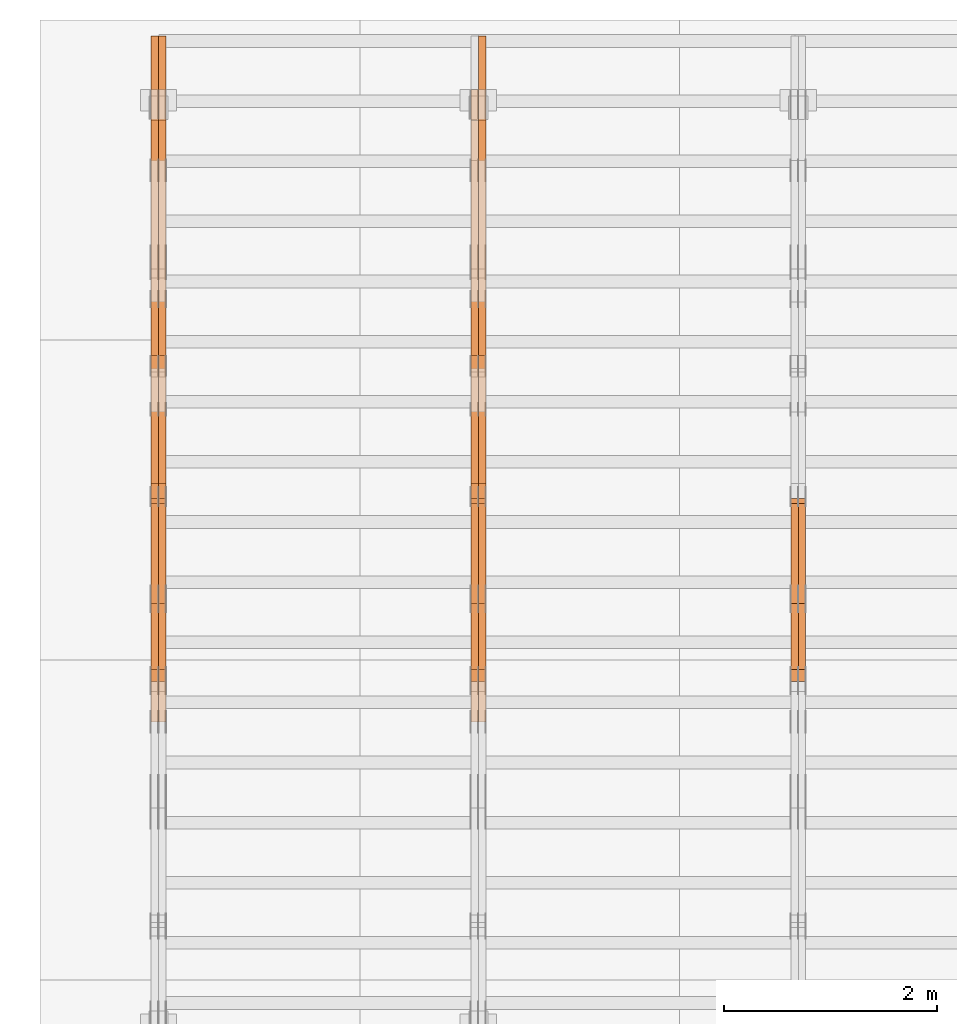
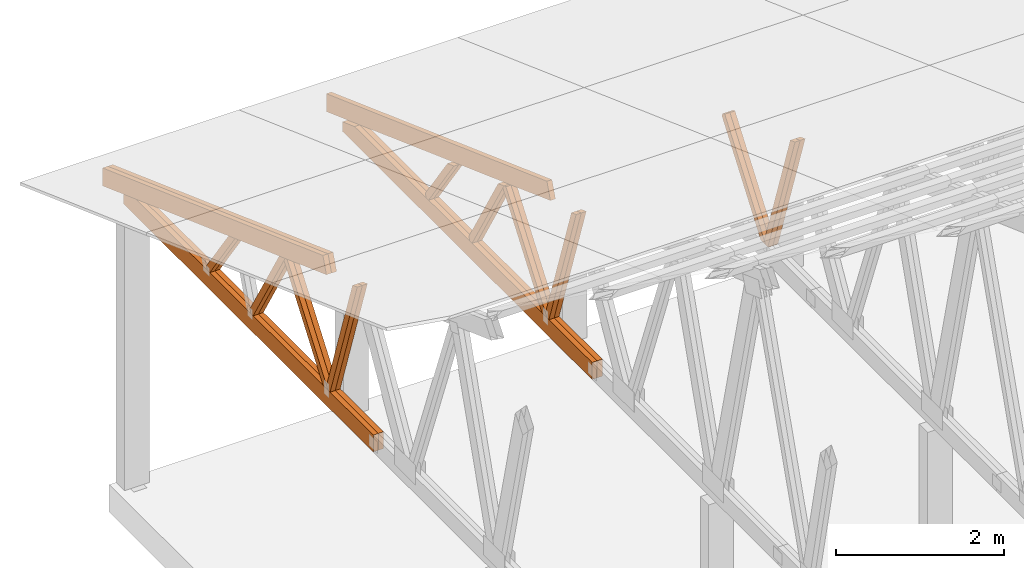
# One storey, part 35 of 189: 27 proxies.
"""IFC2X3 building model written with IfcOpenShell, lengths in millimetres."""

from ifc_helpers import new_model, entity, si_unit, converted_unit, derived_unit, direction, frame, origin, place, context, subcontext, project, spatial, polyline, outline, extrude, source, transform, mapped, material, type_object, type_shapes, element, save


model = new_model("IFC2X3")

# Units and contexts
model_context = context("Model", 3, precision=0.01, world=origin(), true_north=direction((6.12303176911189e-17, 1.0)))
body_context = subcontext(model_context, "Body", "Model", "MODEL_VIEW")
ifc_project = project(units=[si_unit("LENGTHUNIT", "METRE", prefix="MILLI"), si_unit("AREAUNIT", "SQUARE_METRE"), si_unit("VOLUMEUNIT", "CUBIC_METRE"), converted_unit("PLANEANGLEUNIT", "DEGREE", entity("IfcRatioMeasure", 0.0174532925199433), si_unit("PLANEANGLEUNIT", "RADIAN"), dimensions=[0, 0, 0, 0, 0, 0, 0]), si_unit("MASSUNIT", "GRAM", prefix="KILO"), derived_unit("MASSDENSITYUNIT", [(si_unit("MASSUNIT", "GRAM", prefix="KILO"), 1), (si_unit("LENGTHUNIT", "METRE"), -3)]), si_unit("TIMEUNIT", "SECOND"), si_unit("FREQUENCYUNIT", "HERTZ"), si_unit("THERMODYNAMICTEMPERATUREUNIT", "DEGREE_CELSIUS"), derived_unit("THERMALTRANSMITTANCEUNIT", [(si_unit("MASSUNIT", "GRAM", prefix="KILO"), 1), (si_unit("THERMODYNAMICTEMPERATUREUNIT", "KELVIN"), -1), (si_unit("TIMEUNIT", "SECOND"), -3)]), derived_unit("VOLUMETRICFLOWRATEUNIT", [(si_unit("LENGTHUNIT", "METRE"), 3), (si_unit("TIMEUNIT", "SECOND"), -1)]), si_unit("ELECTRICCURRENTUNIT", "AMPERE"), si_unit("ELECTRICVOLTAGEUNIT", "VOLT"), si_unit("POWERUNIT", "WATT"), si_unit("FORCEUNIT", "NEWTON"), si_unit("ILLUMINANCEUNIT", "LUX"), si_unit("LUMINOUSFLUXUNIT", "LUMEN"), si_unit("LUMINOUSINTENSITYUNIT", "CANDELA"), derived_unit("USERDEFINED", [(si_unit("MASSUNIT", "GRAM", prefix="KILO"), -1), (si_unit("LENGTHUNIT", "METRE"), -2), (si_unit("TIMEUNIT", "SECOND"), 3), (si_unit("LUMINOUSFLUXUNIT", "LUMEN"), 1)]), derived_unit("LINEARVELOCITYUNIT", [(si_unit("LENGTHUNIT", "METRE"), 1), (si_unit("TIMEUNIT", "SECOND"), -1)]), si_unit("PRESSUREUNIT", "PASCAL"), derived_unit("USERDEFINED", [(si_unit("LENGTHUNIT", "METRE"), -2), (si_unit("MASSUNIT", "GRAM", prefix="KILO"), 1), (si_unit("TIMEUNIT", "SECOND"), -2)])], contexts=[model_context])

# Site, building, storey
site_placement = place(None, origin())
site = spatial("IfcSite", under=ifc_project, at=site_placement, CompositionType="ELEMENT")
building_placement = place(site_placement, origin())
building = spatial("IfcBuilding", under=site, at=building_placement, CompositionType="ELEMENT")
storey_placement = place(building_placement, origin())
storey = spatial("IfcBuildingStorey", under=building, at=storey_placement, Name="Default", CompositionType="ELEMENT", Elevation=0.0)

# Proxies
ifc_material_1 = material(Name="IfcSurfaceStyle #34810")
building_element_proxy_type_1 = type_object("IfcBuildingElementProxyType", Name="T1-W9 34808", PredefinedType="NOTDEFINED", material=ifc_material_1)
shared_shape_1 = source(origin(), body_context, "Body", "SweptSolid", [
    extrude(outline(polyline([(-1151.44310138162, -47.5000079487596), (776.329826327547, -47.5000079487596), (809.267611644053, -8.1966354137375e-07), (793.242530238244, 47.5000083585914), (-1227.39686682822, 47.5000083585914), (-1151.44310138162, -47.5000079487596)])), frame((809.267685789073, 47.5000083585914, 0.0), z_axis=(0.0, 0.0, 1.0), x_axis=(-1.0, 0.0, 0.0)), (0.0, 0.0, 1.0), 69.9999999999999),
])
type_shapes(building_element_proxy_type_1, [shared_shape_1])
proxy_1_placement = place(building_placement, frame((6335.0, 24600.2198992919, 229.815691184017), z_axis=(-1.0, 0.0, 0.0), x_axis=(0.0, -0.31966811847134, 0.947529574226047)))
element("IfcBuildingElementProxy", 1, at=proxy_1_placement, inside=storey, type_object=building_element_proxy_type_1, material=ifc_material_1, Name="T1-W9", context=body_context, shape_type="MappedRepresentation", body=[
    mapped(shared_shape_1, transform((0.0, 0.0, 0.0), scale=1.0)),
])
ifc_material_2 = material(Name="IfcSurfaceStyle #34744")
building_element_proxy_type_2 = type_object("IfcBuildingElementProxyType", Name="T1-W9 34742", PredefinedType="NOTDEFINED", material=ifc_material_2)
shared_shape_2 = source(origin(), body_context, "Body", "SweptSolid", [
    extrude(outline(polyline([(-1151.44310138162, -47.5000079487596), (776.329826327547, -47.5000079487596), (809.267611644053, -8.1966354137375e-07), (793.242530238244, 47.5000083585914), (-1227.39686682822, 47.5000083585914), (-1151.44310138162, -47.5000079487596)])), frame((809.267685789073, 47.5000083585914, 0.0), z_axis=(0.0, 0.0, 1.0), x_axis=(-1.0, 0.0, 0.0)), (0.0, 0.0, 1.0), 69.9999999999999),
])
type_shapes(building_element_proxy_type_2, [shared_shape_2])
proxy_2_placement = place(building_placement, frame((6265.0, 24600.2198992919, 229.815691184017), z_axis=(-1.0, 0.0, 0.0), x_axis=(0.0, -0.31966811847134, 0.947529574226047)))
element("IfcBuildingElementProxy", 2, at=proxy_2_placement, inside=storey, type_object=building_element_proxy_type_2, material=ifc_material_2, Name="T1-W9", context=body_context, shape_type="MappedRepresentation", body=[
    mapped(shared_shape_2, transform((0.0, 0.0, 0.0), scale=1.0)),
])
ifc_material_3 = material(Name="IfcSurfaceStyle #34546")
building_element_proxy_type_3 = type_object("IfcBuildingElementProxyType", Name="T1-W10 34544", PredefinedType="NOTDEFINED", material=ifc_material_3)
shared_shape_3 = source(origin(), body_context, "Body", "SweptSolid", [
    extrude(outline(polyline([(-993.240970354386, -47.5000757607337), (635.890952815036, -47.5000757607337), (650.068145237537, -1.47580554758164e-05), (629.921374092803, 47.5000831397614), (-922.639501790989, 47.5000831397614), (-993.240970354386, -47.5000757607337)])), frame((650.068173419645, 47.5002811208496, 0.0), z_axis=(0.0, 0.0, 1.0), x_axis=(-1.0, 0.0, 0.0)), (0.0, 0.0, 1.0), 69.9999999999999),
])
type_shapes(building_element_proxy_type_3, [shared_shape_3])
proxy_3_placement = place(building_placement, frame((6335.0, 25701.688098798, 1507.2920009025), z_axis=(-1.0, 0.0, 0.0), x_axis=(0.0, -0.596486092002004, -0.802623412347395)))
element("IfcBuildingElementProxy", 3, at=proxy_3_placement, inside=storey, type_object=building_element_proxy_type_3, material=ifc_material_3, Name="T1-W10", context=body_context, shape_type="MappedRepresentation", body=[
    mapped(shared_shape_3, transform((0.0, 0.0, 0.0), scale=1.0)),
])
ifc_material_4 = material(Name="IfcSurfaceStyle #34480")
building_element_proxy_type_4 = type_object("IfcBuildingElementProxyType", Name="T1-W10 34478", PredefinedType="NOTDEFINED", material=ifc_material_4)
shared_shape_4 = source(origin(), body_context, "Body", "SweptSolid", [
    extrude(outline(polyline([(-993.240970354386, -47.5000757607337), (635.890952815036, -47.5000757607337), (650.068145237537, -1.47580554758164e-05), (629.921374092803, 47.5000831397614), (-922.639501790989, 47.5000831397614), (-993.240970354386, -47.5000757607337)])), frame((650.068173419645, 47.5002811208496, 0.0), z_axis=(0.0, 0.0, 1.0), x_axis=(-1.0, 0.0, 0.0)), (0.0, 0.0, 1.0), 69.9999999999999),
])
type_shapes(building_element_proxy_type_4, [shared_shape_4])
proxy_4_placement = place(building_placement, frame((6265.0, 25701.688098798, 1507.2920009025), z_axis=(-1.0, 0.0, 0.0), x_axis=(0.0, -0.596486092002004, -0.802623412347395)))
element("IfcBuildingElementProxy", 4, at=proxy_4_placement, inside=storey, type_object=building_element_proxy_type_4, material=ifc_material_4, Name="T1-W10", context=body_context, shape_type="MappedRepresentation", body=[
    mapped(shared_shape_4, transform((0.0, 0.0, 0.0), scale=1.0)),
])
ifc_material_5 = material(Name="IfcSurfaceStyle #19020")
building_element_proxy_type_5 = type_object("IfcBuildingElementProxyType", Name="T1-W9 19018", PredefinedType="NOTDEFINED", material=ifc_material_5)
shared_shape_5 = source(origin(), body_context, "Body", "SweptSolid", [
    extrude(outline(polyline([(-1151.44310138162, -47.5000079487596), (776.329826327547, -47.5000079487596), (809.267611644053, -8.1966354137375e-07), (793.242530238244, 47.5000083585914), (-1227.39686682822, 47.5000083585914), (-1151.44310138162, -47.5000079487596)])), frame((809.267685789073, 47.5000083585914, 0.0), z_axis=(0.0, 0.0, 1.0), x_axis=(-1.0, 0.0, 0.0)), (0.0, 0.0, 1.0), 69.9999999999999),
])
type_shapes(building_element_proxy_type_5, [shared_shape_5])
proxy_5_placement = place(building_placement, frame((3335.0, 24600.2198992919, 229.815691184017), z_axis=(-1.0, 0.0, 0.0), x_axis=(0.0, -0.31966811847134, 0.947529574226047)))
element("IfcBuildingElementProxy", 5, at=proxy_5_placement, inside=storey, type_object=building_element_proxy_type_5, material=ifc_material_5, Name="T1-W9", context=body_context, shape_type="MappedRepresentation", body=[
    mapped(shared_shape_5, transform((0.0, 0.0, 0.0), scale=1.0)),
])
ifc_material_6 = material(Name="IfcSurfaceStyle #18954")
building_element_proxy_type_6 = type_object("IfcBuildingElementProxyType", Name="T1-W9 18952", PredefinedType="NOTDEFINED", material=ifc_material_6)
shared_shape_6 = source(origin(), body_context, "Body", "SweptSolid", [
    extrude(outline(polyline([(-1151.44310138162, -47.5000079487596), (776.329826327547, -47.5000079487596), (809.267611644053, -8.1966354137375e-07), (793.242530238244, 47.5000083585914), (-1227.39686682822, 47.5000083585914), (-1151.44310138162, -47.5000079487596)])), frame((809.267685789073, 47.5000083585914, 0.0), z_axis=(0.0, 0.0, 1.0), x_axis=(-1.0, 0.0, 0.0)), (0.0, 0.0, 1.0), 69.9999999999999),
])
type_shapes(building_element_proxy_type_6, [shared_shape_6])
proxy_6_placement = place(building_placement, frame((3265.0, 24600.2198992919, 229.815691184017), z_axis=(-1.0, 0.0, 0.0), x_axis=(0.0, -0.31966811847134, 0.947529574226047)))
element("IfcBuildingElementProxy", 6, at=proxy_6_placement, inside=storey, type_object=building_element_proxy_type_6, material=ifc_material_6, Name="T1-W9", context=body_context, shape_type="MappedRepresentation", body=[
    mapped(shared_shape_6, transform((0.0, 0.0, 0.0), scale=1.0)),
])
ifc_material_7 = material(Name="IfcSurfaceStyle #18756")
building_element_proxy_type_7 = type_object("IfcBuildingElementProxyType", Name="T1-W10 18754", PredefinedType="NOTDEFINED", material=ifc_material_7)
shared_shape_7 = source(origin(), body_context, "Body", "SweptSolid", [
    extrude(outline(polyline([(-993.240970354386, -47.5000757607337), (635.890952815036, -47.5000757607337), (650.068145237537, -1.47580554758164e-05), (629.921374092803, 47.5000831397614), (-922.639501790989, 47.5000831397614), (-993.240970354386, -47.5000757607337)])), frame((650.068173419645, 47.5002811208496, 0.0), z_axis=(0.0, 0.0, 1.0), x_axis=(-1.0, 0.0, 0.0)), (0.0, 0.0, 1.0), 69.9999999999999),
])
type_shapes(building_element_proxy_type_7, [shared_shape_7])
proxy_7_placement = place(building_placement, frame((3335.0, 25701.688098798, 1507.2920009025), z_axis=(-1.0, 0.0, 0.0), x_axis=(0.0, -0.596486092002004, -0.802623412347395)))
element("IfcBuildingElementProxy", 7, at=proxy_7_placement, inside=storey, type_object=building_element_proxy_type_7, material=ifc_material_7, Name="T1-W10", context=body_context, shape_type="MappedRepresentation", body=[
    mapped(shared_shape_7, transform((0.0, 0.0, 0.0), scale=1.0)),
])
ifc_material_8 = material(Name="IfcSurfaceStyle #18690")
building_element_proxy_type_8 = type_object("IfcBuildingElementProxyType", Name="T1-W10 18688", PredefinedType="NOTDEFINED", material=ifc_material_8)
shared_shape_8 = source(origin(), body_context, "Body", "SweptSolid", [
    extrude(outline(polyline([(-993.240970354386, -47.5000757607337), (635.890952815036, -47.5000757607337), (650.068145237537, -1.47580554758164e-05), (629.921374092803, 47.5000831397614), (-922.639501790989, 47.5000831397614), (-993.240970354386, -47.5000757607337)])), frame((650.068173419645, 47.5002811208496, 0.0), z_axis=(0.0, 0.0, 1.0), x_axis=(-1.0, 0.0, 0.0)), (0.0, 0.0, 1.0), 69.9999999999999),
])
type_shapes(building_element_proxy_type_8, [shared_shape_8])
proxy_8_placement = place(building_placement, frame((3265.0, 25701.688098798, 1507.2920009025), z_axis=(-1.0, 0.0, 0.0), x_axis=(0.0, -0.596486092002004, -0.802623412347395)))
element("IfcBuildingElementProxy", 8, at=proxy_8_placement, inside=storey, type_object=building_element_proxy_type_8, material=ifc_material_8, Name="T1-W10", context=body_context, shape_type="MappedRepresentation", body=[
    mapped(shared_shape_8, transform((0.0, 0.0, 0.0), scale=1.0)),
])
ifc_material_9 = material(Name="IfcSurfaceStyle #18492")
building_element_proxy_type_9 = type_object("IfcBuildingElementProxyType", Name="T1-W11 18490", PredefinedType="NOTDEFINED", material=ifc_material_9)
shared_shape_9 = source(origin(), body_context, "Body", "SweptSolid", [
    extrude(outline(polyline([(-809.410890003667, -47.5000077306544), (561.624013869753, -47.5000077306544), (599.944137054867, -7.52294285037536e-05), (572.078784657538, 47.5000453453687), (-924.236045578491, 47.5000453453687), (-809.410890003667, -47.5000077306544)])), frame((599.944137054867, 47.5000453453687, 0.0), z_axis=(0.0, 0.0, 1.0), x_axis=(-1.0, 0.0, 0.0)), (0.0, 0.0, 1.0), 69.9999999999999),
])
type_shapes(building_element_proxy_type_9, [shared_shape_9])
proxy_9_placement = place(building_placement, frame((3335.0, 26434.7921369083, 220.965133687368), z_axis=(-1.0, 0.0, 0.0), x_axis=(0.0, -0.505995901100603, 0.862535882192381)))
element("IfcBuildingElementProxy", 9, at=proxy_9_placement, inside=storey, type_object=building_element_proxy_type_9, material=ifc_material_9, Name="T1-W11", context=body_context, shape_type="MappedRepresentation", body=[
    mapped(shared_shape_9, transform((0.0, 0.0, 0.0), scale=1.0)),
])
ifc_material_10 = material(Name="IfcSurfaceStyle #18426")
building_element_proxy_type_10 = type_object("IfcBuildingElementProxyType", Name="T1-W11 18424", PredefinedType="NOTDEFINED", material=ifc_material_10)
shared_shape_10 = source(origin(), body_context, "Body", "SweptSolid", [
    extrude(outline(polyline([(-809.410890003667, -47.5000077306544), (561.624013869753, -47.5000077306544), (599.944137054867, -7.52294285037536e-05), (572.078784657538, 47.5000453453687), (-924.236045578491, 47.5000453453687), (-809.410890003667, -47.5000077306544)])), frame((599.944137054867, 47.5000453453687, 0.0), z_axis=(0.0, 0.0, 1.0), x_axis=(-1.0, 0.0, 0.0)), (0.0, 0.0, 1.0), 69.9999999999999),
])
type_shapes(building_element_proxy_type_10, [shared_shape_10])
proxy_10_placement = place(building_placement, frame((3265.0, 26434.7921369083, 220.965133687368), z_axis=(-1.0, 0.0, 0.0), x_axis=(0.0, -0.505995901100603, 0.862535882192381)))
element("IfcBuildingElementProxy", 10, at=proxy_10_placement, inside=storey, type_object=building_element_proxy_type_10, material=ifc_material_10, Name="T1-W11", context=body_context, shape_type="MappedRepresentation", body=[
    mapped(shared_shape_10, transform((0.0, 0.0, 0.0), scale=1.0)),
])
ifc_material_11 = material(Name="IfcSurfaceStyle #17964")
building_element_proxy_type_11 = type_object("IfcBuildingElementProxyType", Name="T1-W13 17962", PredefinedType="NOTDEFINED", material=ifc_material_11)
shared_shape_11 = source(origin(), body_context, "Body", "SweptSolid", [
    extrude(outline(polyline([(-527.416466728212, -47.5000272833949), (387.658053197984, -47.5000272833949), (418.029495084182, -7.96824534414764e-06), (384.779443025059, 47.5000312675175), (-663.050524579013, 47.5000312675176), (-527.416466728212, -47.5000272833949)])), frame((418.029495084182, 47.5000671658844, 0.0), z_axis=(0.0, 0.0, 1.0), x_axis=(-1.0, 0.0, 0.0)), (0.0, 0.0, 1.0), 69.9999999999999),
])
type_shapes(building_element_proxy_type_11, [shared_shape_11])
proxy_11_placement = place(building_placement, frame((3335.0, 27471.0085508293, 217.760482033818), z_axis=(-1.0, 0.0, 0.0), x_axis=(0.0, -0.573462629043498, 0.819231721242848)))
element("IfcBuildingElementProxy", 11, at=proxy_11_placement, inside=storey, type_object=building_element_proxy_type_11, material=ifc_material_11, Name="T1-W13", context=body_context, shape_type="MappedRepresentation", body=[
    mapped(shared_shape_11, transform((0.0, 0.0, 0.0), scale=1.0)),
])
ifc_material_12 = material(Name="IfcSurfaceStyle #17898")
building_element_proxy_type_12 = type_object("IfcBuildingElementProxyType", Name="T1-W13 17896", PredefinedType="NOTDEFINED", material=ifc_material_12)
shared_shape_12 = source(origin(), body_context, "Body", "SweptSolid", [
    extrude(outline(polyline([(-527.416466728212, -47.5000272833949), (387.658053197984, -47.5000272833949), (418.029495084182, -7.96824534414764e-06), (384.779443025059, 47.5000312675175), (-663.050524579013, 47.5000312675176), (-527.416466728212, -47.5000272833949)])), frame((418.029495084182, 47.5000671658844, 0.0), z_axis=(0.0, 0.0, 1.0), x_axis=(-1.0, 0.0, 0.0)), (0.0, 0.0, 1.0), 69.9999999999999),
])
type_shapes(building_element_proxy_type_12, [shared_shape_12])
proxy_12_placement = place(building_placement, frame((3265.0, 27471.0085508293, 217.760482033818), z_axis=(-1.0, 0.0, 0.0), x_axis=(0.0, -0.573462629043498, 0.819231721242848)))
element("IfcBuildingElementProxy", 12, at=proxy_12_placement, inside=storey, type_object=building_element_proxy_type_12, material=ifc_material_12, Name="T1-W13", context=body_context, shape_type="MappedRepresentation", body=[
    mapped(shared_shape_12, transform((0.0, 0.0, 0.0), scale=1.0)),
])
ifc_material_13 = material(Name="IfcSurfaceStyle #17340")
building_element_proxy_type_13 = type_object("IfcBuildingElementProxyType", Name="T1-B1 17338", PredefinedType="NOTDEFINED", material=ifc_material_13)
shared_shape_13 = source(origin(), body_context, "Body", "SweptSolid", [
    extrude(outline(polyline([(-2430.09461669922, -125.855288696288), (3499.90538330078, -125.855288696288), (3499.90538330078, 119.144711303711), (-2139.62153320312, 119.144711303711), (-2430.09461669922, 13.4211547851552), (-2430.09461669922, -125.855288696288)])), frame((3499.90538330078, 119.144711303711, 0.0), z_axis=(0.0, 0.0, 1.0), x_axis=(-1.0, 0.0, 0.0)), (0.0, 0.0, 1.0), 69.9999999999996),
])
type_shapes(building_element_proxy_type_13, [shared_shape_13])
proxy_13_placement = place(building_placement, frame((3335.0, 23570.0, 245.0), z_axis=(-1.0, 0.0, 0.0), x_axis=(0.0, 1.0, 0.0)))
element("IfcBuildingElementProxy", 13, at=proxy_13_placement, inside=storey, type_object=building_element_proxy_type_13, material=ifc_material_13, Name="T1-B1", context=body_context, shape_type="MappedRepresentation", body=[
    mapped(shared_shape_13, transform((0.0, 0.0, 0.0), scale=1.0)),
])
ifc_material_14 = material(Name="IfcSurfaceStyle #17274")
building_element_proxy_type_14 = type_object("IfcBuildingElementProxyType", Name="T1-B1 17272", PredefinedType="NOTDEFINED", material=ifc_material_14)
shared_shape_14 = source(origin(), body_context, "Body", "SweptSolid", [
    extrude(outline(polyline([(-2430.09461669922, -125.855288696288), (3499.90538330078, -125.855288696288), (3499.90538330078, 119.144711303711), (-2139.62153320312, 119.144711303711), (-2430.09461669922, 13.4211547851552), (-2430.09461669922, -125.855288696288)])), frame((3499.90538330078, 119.144711303711, 0.0), z_axis=(0.0, 0.0, 1.0), x_axis=(-1.0, 0.0, 0.0)), (0.0, 0.0, 1.0), 69.9999999999996),
])
type_shapes(building_element_proxy_type_14, [shared_shape_14])
proxy_14_placement = place(building_placement, frame((3265.0, 23570.0, 245.0), z_axis=(-1.0, 0.0, 0.0), x_axis=(0.0, 1.0, 0.0)))
element("IfcBuildingElementProxy", 14, at=proxy_14_placement, inside=storey, type_object=building_element_proxy_type_14, material=ifc_material_14, Name="T1-B1", context=body_context, shape_type="MappedRepresentation", body=[
    mapped(shared_shape_14, transform((0.0, 0.0, 0.0), scale=1.0)),
])
ifc_material_15 = material(Name="IfcSurfaceStyle #16050")
building_element_proxy_type_15 = type_object("IfcBuildingElementProxyType", Name="T1-T2 16048", PredefinedType="NOTDEFINED", material=ifc_material_15)
shared_shape_15 = source(origin(), body_context, "Body", "SweptSolid", [
    extrude(outline(polyline([(-2807.70681121203, -122.500041939424), (2763.12044548192, -122.500041939424), (2852.29315104137, 122.500041939424), (-2807.70678531126, 122.500041939424), (-2807.70681121203, -122.500041939424)])), frame((2852.29315104137, 122.500041939424, 0.0), z_axis=(0.0, 0.0, 1.0), x_axis=(-1.0, 0.0, 0.0)), (0.0, 0.0, 1.0), 69.9999999999997),
])
type_shapes(building_element_proxy_type_15, [shared_shape_15])
proxy_15_placement = place(building_placement, frame((3335.0, 30000.0, -42.7086715698242), z_axis=(-1.0, 0.0, 0.0), x_axis=(0.0, -0.939692620785908, 0.342020143325669)))
element("IfcBuildingElementProxy", 15, at=proxy_15_placement, inside=storey, type_object=building_element_proxy_type_15, material=ifc_material_15, Name="T1-T2", context=body_context, shape_type="MappedRepresentation", body=[
    mapped(shared_shape_15, transform((0.0, 0.0, 0.0), scale=1.0)),
])
ifc_material_16 = material(Name="IfcSurfaceStyle #3227")
building_element_proxy_type_16 = type_object("IfcBuildingElementProxyType", Name="T1-W9 3225", PredefinedType="NOTDEFINED", material=ifc_material_16)
shared_shape_16 = source(origin(), body_context, "Body", "SweptSolid", [
    extrude(outline(polyline([(-1151.44310138162, -47.5000079487596), (776.329826327547, -47.5000079487596), (809.267611644053, -8.1966354137375e-07), (793.242530238244, 47.5000083585914), (-1227.39686682822, 47.5000083585914), (-1151.44310138162, -47.5000079487596)])), frame((809.267685789073, 47.5000083585914, 0.0), z_axis=(0.0, 0.0, 1.0), x_axis=(-1.0, 0.0, 0.0)), (0.0, 0.0, 1.0), 69.9999999999999),
])
type_shapes(building_element_proxy_type_16, [shared_shape_16])
proxy_16_placement = place(building_placement, frame((335.0, 24600.2198992919, 229.815691184017), z_axis=(-1.0, 0.0, 0.0), x_axis=(0.0, -0.31966811847134, 0.947529574226047)))
element("IfcBuildingElementProxy", 16, at=proxy_16_placement, inside=storey, type_object=building_element_proxy_type_16, material=ifc_material_16, Name="T1-W9", context=body_context, shape_type="MappedRepresentation", body=[
    mapped(shared_shape_16, transform((0.0, 0.0, 0.0), scale=1.0)),
])
ifc_material_17 = material(Name="IfcSurfaceStyle #3161")
building_element_proxy_type_17 = type_object("IfcBuildingElementProxyType", Name="T1-W9 3159", PredefinedType="NOTDEFINED", material=ifc_material_17)
shared_shape_17 = source(origin(), body_context, "Body", "SweptSolid", [
    extrude(outline(polyline([(-1151.44310138162, -47.5000079487596), (776.329826327547, -47.5000079487596), (809.267611644053, -8.1966354137375e-07), (793.242530238244, 47.5000083585914), (-1227.39686682822, 47.5000083585914), (-1151.44310138162, -47.5000079487596)])), frame((809.267685789073, 47.5000083585914, 0.0), z_axis=(0.0, 0.0, 1.0), x_axis=(-1.0, 0.0, 0.0)), (0.0, 0.0, 1.0), 69.9999999999999),
])
type_shapes(building_element_proxy_type_17, [shared_shape_17])
proxy_17_placement = place(building_placement, frame((265.0, 24600.2198992919, 229.815691184017), z_axis=(-1.0, 0.0, 0.0), x_axis=(0.0, -0.31966811847134, 0.947529574226047)))
element("IfcBuildingElementProxy", 17, at=proxy_17_placement, inside=storey, type_object=building_element_proxy_type_17, material=ifc_material_17, Name="T1-W9", context=body_context, shape_type="MappedRepresentation", body=[
    mapped(shared_shape_17, transform((0.0, 0.0, 0.0), scale=1.0)),
])
ifc_material_18 = material(Name="IfcSurfaceStyle #2963")
building_element_proxy_type_18 = type_object("IfcBuildingElementProxyType", Name="T1-W10 2961", PredefinedType="NOTDEFINED", material=ifc_material_18)
shared_shape_18 = source(origin(), body_context, "Body", "SweptSolid", [
    extrude(outline(polyline([(-993.240970354386, -47.5000757607337), (635.890952815036, -47.5000757607337), (650.068145237537, -1.47580554758164e-05), (629.921374092803, 47.5000831397614), (-922.639501790989, 47.5000831397614), (-993.240970354386, -47.5000757607337)])), frame((650.068173419645, 47.5002811208496, 0.0), z_axis=(0.0, 0.0, 1.0), x_axis=(-1.0, 0.0, 0.0)), (0.0, 0.0, 1.0), 69.9999999999999),
])
type_shapes(building_element_proxy_type_18, [shared_shape_18])
proxy_18_placement = place(building_placement, frame((335.0, 25701.688098798, 1507.2920009025), z_axis=(-1.0, 0.0, 0.0), x_axis=(0.0, -0.596486092002004, -0.802623412347395)))
element("IfcBuildingElementProxy", 18, at=proxy_18_placement, inside=storey, type_object=building_element_proxy_type_18, material=ifc_material_18, Name="T1-W10", context=body_context, shape_type="MappedRepresentation", body=[
    mapped(shared_shape_18, transform((0.0, 0.0, 0.0), scale=1.0)),
])
ifc_material_19 = material(Name="IfcSurfaceStyle #2897")
building_element_proxy_type_19 = type_object("IfcBuildingElementProxyType", Name="T1-W10 2895", PredefinedType="NOTDEFINED", material=ifc_material_19)
shared_shape_19 = source(origin(), body_context, "Body", "SweptSolid", [
    extrude(outline(polyline([(-993.240970354386, -47.5000757607337), (635.890952815036, -47.5000757607337), (650.068145237537, -1.47580554758164e-05), (629.921374092803, 47.5000831397614), (-922.639501790989, 47.5000831397614), (-993.240970354386, -47.5000757607337)])), frame((650.068173419645, 47.5002811208496, 0.0), z_axis=(0.0, 0.0, 1.0), x_axis=(-1.0, 0.0, 0.0)), (0.0, 0.0, 1.0), 69.9999999999999),
])
type_shapes(building_element_proxy_type_19, [shared_shape_19])
proxy_19_placement = place(building_placement, frame((265.0, 25701.688098798, 1507.2920009025), z_axis=(-1.0, 0.0, 0.0), x_axis=(0.0, -0.596486092002004, -0.802623412347395)))
element("IfcBuildingElementProxy", 19, at=proxy_19_placement, inside=storey, type_object=building_element_proxy_type_19, material=ifc_material_19, Name="T1-W10", context=body_context, shape_type="MappedRepresentation", body=[
    mapped(shared_shape_19, transform((0.0, 0.0, 0.0), scale=1.0)),
])
ifc_material_20 = material(Name="IfcSurfaceStyle #2699")
building_element_proxy_type_20 = type_object("IfcBuildingElementProxyType", Name="T1-W11 2697", PredefinedType="NOTDEFINED", material=ifc_material_20)
shared_shape_20 = source(origin(), body_context, "Body", "SweptSolid", [
    extrude(outline(polyline([(-809.410890003667, -47.5000077306544), (561.624013869753, -47.5000077306544), (599.944137054867, -7.52294285037536e-05), (572.078784657538, 47.5000453453687), (-924.236045578491, 47.5000453453687), (-809.410890003667, -47.5000077306544)])), frame((599.944137054867, 47.5000453453687, 0.0), z_axis=(0.0, 0.0, 1.0), x_axis=(-1.0, 0.0, 0.0)), (0.0, 0.0, 1.0), 69.9999999999999),
])
type_shapes(building_element_proxy_type_20, [shared_shape_20])
proxy_20_placement = place(building_placement, frame((335.0, 26434.7921369083, 220.965133687368), z_axis=(-1.0, 0.0, 0.0), x_axis=(0.0, -0.505995901100603, 0.862535882192381)))
element("IfcBuildingElementProxy", 20, at=proxy_20_placement, inside=storey, type_object=building_element_proxy_type_20, material=ifc_material_20, Name="T1-W11", context=body_context, shape_type="MappedRepresentation", body=[
    mapped(shared_shape_20, transform((0.0, 0.0, 0.0), scale=1.0)),
])
ifc_material_21 = material(Name="IfcSurfaceStyle #2633")
building_element_proxy_type_21 = type_object("IfcBuildingElementProxyType", Name="T1-W11 2631", PredefinedType="NOTDEFINED", material=ifc_material_21)
shared_shape_21 = source(origin(), body_context, "Body", "SweptSolid", [
    extrude(outline(polyline([(-809.410890003667, -47.5000077306544), (561.624013869753, -47.5000077306544), (599.944137054867, -7.52294285037536e-05), (572.078784657538, 47.5000453453687), (-924.236045578491, 47.5000453453687), (-809.410890003667, -47.5000077306544)])), frame((599.944137054867, 47.5000453453687, 0.0), z_axis=(0.0, 0.0, 1.0), x_axis=(-1.0, 0.0, 0.0)), (0.0, 0.0, 1.0), 69.9999999999999),
])
type_shapes(building_element_proxy_type_21, [shared_shape_21])
proxy_21_placement = place(building_placement, frame((265.0, 26434.7921369083, 220.965133687368), z_axis=(-1.0, 0.0, 0.0), x_axis=(0.0, -0.505995901100603, 0.862535882192381)))
element("IfcBuildingElementProxy", 21, at=proxy_21_placement, inside=storey, type_object=building_element_proxy_type_21, material=ifc_material_21, Name="T1-W11", context=body_context, shape_type="MappedRepresentation", body=[
    mapped(shared_shape_21, transform((0.0, 0.0, 0.0), scale=1.0)),
])
ifc_material_22 = material(Name="IfcSurfaceStyle #2171")
building_element_proxy_type_22 = type_object("IfcBuildingElementProxyType", Name="T1-W13 2169", PredefinedType="NOTDEFINED", material=ifc_material_22)
shared_shape_22 = source(origin(), body_context, "Body", "SweptSolid", [
    extrude(outline(polyline([(-527.416466728212, -47.5000272833949), (387.658053197984, -47.5000272833949), (418.029495084182, -7.96824534414764e-06), (384.779443025059, 47.5000312675175), (-663.050524579013, 47.5000312675176), (-527.416466728212, -47.5000272833949)])), frame((418.029495084182, 47.5000671658844, 0.0), z_axis=(0.0, 0.0, 1.0), x_axis=(-1.0, 0.0, 0.0)), (0.0, 0.0, 1.0), 69.9999999999999),
])
type_shapes(building_element_proxy_type_22, [shared_shape_22])
proxy_22_placement = place(building_placement, frame((335.0, 27471.0085508293, 217.760482033818), z_axis=(-1.0, 0.0, 0.0), x_axis=(0.0, -0.573462629043498, 0.819231721242848)))
element("IfcBuildingElementProxy", 22, at=proxy_22_placement, inside=storey, type_object=building_element_proxy_type_22, material=ifc_material_22, Name="T1-W13", context=body_context, shape_type="MappedRepresentation", body=[
    mapped(shared_shape_22, transform((0.0, 0.0, 0.0), scale=1.0)),
])
ifc_material_23 = material(Name="IfcSurfaceStyle #2105")
building_element_proxy_type_23 = type_object("IfcBuildingElementProxyType", Name="T1-W13 2103", PredefinedType="NOTDEFINED", material=ifc_material_23)
shared_shape_23 = source(origin(), body_context, "Body", "SweptSolid", [
    extrude(outline(polyline([(-527.416466728212, -47.5000272833949), (387.658053197984, -47.5000272833949), (418.029495084182, -7.96824534414764e-06), (384.779443025059, 47.5000312675175), (-663.050524579013, 47.5000312675176), (-527.416466728212, -47.5000272833949)])), frame((418.029495084182, 47.5000671658844, 0.0), z_axis=(0.0, 0.0, 1.0), x_axis=(-1.0, 0.0, 0.0)), (0.0, 0.0, 1.0), 69.9999999999999),
])
type_shapes(building_element_proxy_type_23, [shared_shape_23])
proxy_23_placement = place(building_placement, frame((265.0, 27471.0085508293, 217.760482033818), z_axis=(-1.0, 0.0, 0.0), x_axis=(0.0, -0.573462629043498, 0.819231721242848)))
element("IfcBuildingElementProxy", 23, at=proxy_23_placement, inside=storey, type_object=building_element_proxy_type_23, material=ifc_material_23, Name="T1-W13", context=body_context, shape_type="MappedRepresentation", body=[
    mapped(shared_shape_23, transform((0.0, 0.0, 0.0), scale=1.0)),
])
ifc_material_24 = material(Name="IfcSurfaceStyle #1547")
building_element_proxy_type_24 = type_object("IfcBuildingElementProxyType", Name="T1-B1 1545", PredefinedType="NOTDEFINED", material=ifc_material_24)
shared_shape_24 = source(origin(), body_context, "Body", "SweptSolid", [
    extrude(outline(polyline([(-2430.09461669922, -125.855288696288), (3499.90538330078, -125.855288696288), (3499.90538330078, 119.144711303711), (-2139.62153320312, 119.144711303711), (-2430.09461669922, 13.4211547851552), (-2430.09461669922, -125.855288696288)])), frame((3499.90538330078, 119.144711303711, 0.0), z_axis=(0.0, 0.0, 1.0), x_axis=(-1.0, 0.0, 0.0)), (0.0, 0.0, 1.0), 69.9999999999996),
])
type_shapes(building_element_proxy_type_24, [shared_shape_24])
proxy_24_placement = place(building_placement, frame((335.0, 23570.0, 245.0), z_axis=(-1.0, 0.0, 0.0), x_axis=(0.0, 1.0, 0.0)))
element("IfcBuildingElementProxy", 24, at=proxy_24_placement, inside=storey, type_object=building_element_proxy_type_24, material=ifc_material_24, Name="T1-B1", context=body_context, shape_type="MappedRepresentation", body=[
    mapped(shared_shape_24, transform((0.0, 0.0, 0.0), scale=1.0)),
])
ifc_material_25 = material(Name="IfcSurfaceStyle #1481")
building_element_proxy_type_25 = type_object("IfcBuildingElementProxyType", Name="T1-B1 1479", PredefinedType="NOTDEFINED", material=ifc_material_25)
shared_shape_25 = source(origin(), body_context, "Body", "SweptSolid", [
    extrude(outline(polyline([(-2430.09461669922, -125.855288696288), (3499.90538330078, -125.855288696288), (3499.90538330078, 119.144711303711), (-2139.62153320312, 119.144711303711), (-2430.09461669922, 13.4211547851552), (-2430.09461669922, -125.855288696288)])), frame((3499.90538330078, 119.144711303711, 0.0), z_axis=(0.0, 0.0, 1.0), x_axis=(-1.0, 0.0, 0.0)), (0.0, 0.0, 1.0), 69.9999999999996),
])
type_shapes(building_element_proxy_type_25, [shared_shape_25])
proxy_25_placement = place(building_placement, frame((265.0, 23570.0, 245.0), z_axis=(-1.0, 0.0, 0.0), x_axis=(0.0, 1.0, 0.0)))
element("IfcBuildingElementProxy", 25, at=proxy_25_placement, inside=storey, type_object=building_element_proxy_type_25, material=ifc_material_25, Name="T1-B1", context=body_context, shape_type="MappedRepresentation", body=[
    mapped(shared_shape_25, transform((0.0, 0.0, 0.0), scale=1.0)),
])
ifc_material_26 = material(Name="IfcSurfaceStyle #257")
building_element_proxy_type_26 = type_object("IfcBuildingElementProxyType", Name="T1-T2 255", PredefinedType="NOTDEFINED", material=ifc_material_26)
shared_shape_26 = source(origin(), body_context, "Body", "SweptSolid", [
    extrude(outline(polyline([(-2807.70681121203, -122.500041939424), (2763.12044548192, -122.500041939424), (2852.29315104137, 122.500041939424), (-2807.70678531126, 122.500041939424), (-2807.70681121203, -122.500041939424)])), frame((2852.29315104137, 122.500041939424, 0.0), z_axis=(0.0, 0.0, 1.0), x_axis=(-1.0, 0.0, 0.0)), (0.0, 0.0, 1.0), 69.9999999999997),
])
type_shapes(building_element_proxy_type_26, [shared_shape_26])
proxy_26_placement = place(building_placement, frame((335.0, 30000.0, -42.7086715698242), z_axis=(-1.0, 0.0, 0.0), x_axis=(0.0, -0.939692620785908, 0.342020143325669)))
element("IfcBuildingElementProxy", 26, at=proxy_26_placement, inside=storey, type_object=building_element_proxy_type_26, material=ifc_material_26, Name="T1-T2", context=body_context, shape_type="MappedRepresentation", body=[
    mapped(shared_shape_26, transform((0.0, 0.0, 0.0), scale=1.0)),
])
ifc_material_27 = material(Name="IfcSurfaceStyle #200")
building_element_proxy_type_27 = type_object("IfcBuildingElementProxyType", Name="T1-T2 198", PredefinedType="NOTDEFINED", material=ifc_material_27)
shared_shape_27 = source(origin(), body_context, "Body", "SweptSolid", [
    extrude(outline(polyline([(-2807.70681121203, -122.500041939424), (2763.12044548192, -122.500041939424), (2852.29315104137, 122.500041939424), (-2807.70678531126, 122.500041939424), (-2807.70681121203, -122.500041939424)])), frame((2852.29315104137, 122.500041939424, 0.0), z_axis=(0.0, 0.0, 1.0), x_axis=(-1.0, 0.0, 0.0)), (0.0, 0.0, 1.0), 69.9999999999997),
])
type_shapes(building_element_proxy_type_27, [shared_shape_27])
proxy_27_placement = place(building_placement, frame((265.0, 30000.0, -42.7086715698242), z_axis=(-1.0, 0.0, 0.0), x_axis=(0.0, -0.939692620785908, 0.342020143325669)))
element("IfcBuildingElementProxy", 27, at=proxy_27_placement, inside=storey, type_object=building_element_proxy_type_27, material=ifc_material_27, Name="T1-T2", context=body_context, shape_type="MappedRepresentation", body=[
    mapped(shared_shape_27, transform((0.0, 0.0, 0.0), scale=1.0)),
])

save(model, "model.ifc")
